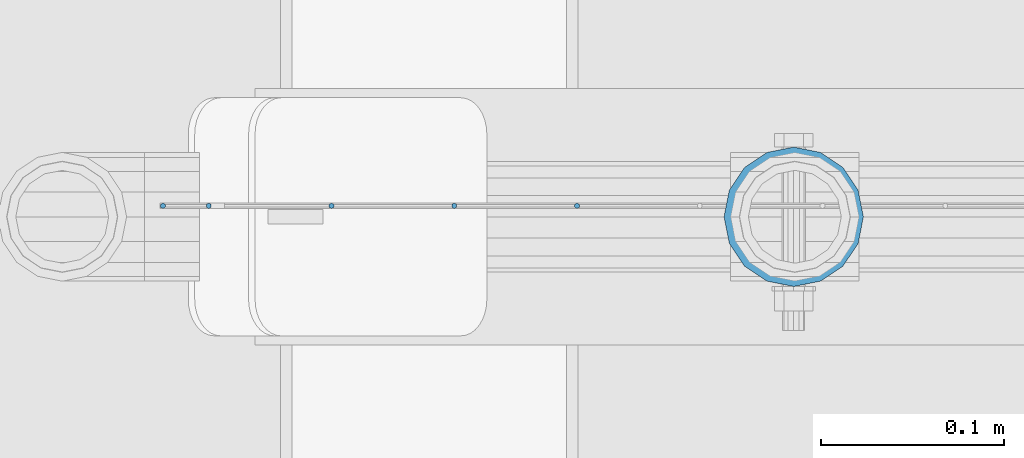
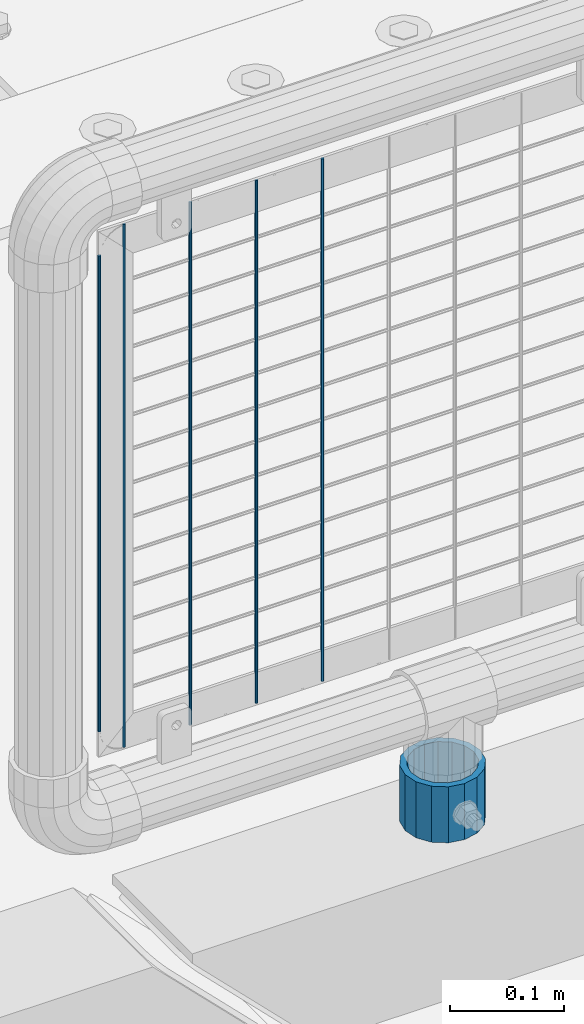
# One storey, part 110 of 270: 6 columns.
"""IFC2X3 building model written with IfcOpenShell, lengths in millimetres."""

from ifc_helpers import new_model, si_unit, frame, origin_with_axes, place, context, subcontext, project, spatial, faceted_brep, material, type_object, element, save


model = new_model("IFC2X3")

# Units and contexts
model_context = context("Model", 3, precision=1e-05, world=origin_with_axes())
body_context = subcontext(model_context, "Body", "Model", "MODEL_VIEW")
ifc_project = project(units=[si_unit("LENGTHUNIT", "METRE", prefix="MILLI"), si_unit("AREAUNIT", "SQUARE_METRE"), si_unit("VOLUMEUNIT", "CUBIC_METRE"), si_unit("MASSUNIT", "GRAM", prefix="KILO"), si_unit("TIMEUNIT", "SECOND"), si_unit("PLANEANGLEUNIT", "RADIAN"), si_unit("SOLIDANGLEUNIT", "STERADIAN"), si_unit("THERMODYNAMICTEMPERATUREUNIT", "DEGREE_CELSIUS"), si_unit("LUMINOUSINTENSITYUNIT", "LUMEN")], contexts=[model_context])

# Site, building, storey
site_placement = place(None, origin_with_axes())
site = spatial("IfcSite", under=ifc_project, at=site_placement, CompositionType="ELEMENT")
building_placement = place(site_placement, origin_with_axes())
building = spatial("IfcBuilding", under=site, at=building_placement, Name="Standard", CompositionType="ELEMENT")
storey_placement = place(building_placement, origin_with_axes())
storey = spatial("IfcBuildingStorey", under=building, at=storey_placement, Name="Undefined", CompositionType="ELEMENT", Elevation=0.0)

# Columns
ifc_material_1 = material()
column_type_1 = type_object("IfcColumnType", PredefinedType="NOTDEFINED")
column_1_placement = place(storey_placement, frame((19094.0, -16335.5, 168.019999999998), z_axis=(0.0, 1.0, 0.0), x_axis=(0.0, 0.0, 1.0)))
element("IfcColumn", 1, at=column_1_placement, inside=storey, type_object=column_type_1, material=ifc_material_1, context=body_context, shape_type="Brep", body=[
    faceted_brep([(0.0, -31.75, 0.0), (0.0, -29.3331751572332, 12.1501989775916), (60.0, -29.3331751572332, 12.1501989775916), (60.0, -31.75, 0.0), (0.0, -22.4506403026717, 22.4506403026735), (60.0, -22.4506403026717, 22.4506403026735), (0.0, -12.1501989775934, 29.3331751572332), (60.0, -12.1501989775934, 29.3331751572332), (0.0, 0.0, 31.75), (60.0, 0.0, 31.75), (0.0, 12.1501989775934, 29.3331751572332), (60.0, 12.1501989775934, 29.3331751572332), (0.0, 22.4506403026717, 22.4506403026735), (60.0, 22.4506403026717, 22.4506403026735), (0.0, 29.3331751572332, 12.1501989775916), (60.0, 29.3331751572332, 12.1501989775916), (0.0, 31.75, 0.0), (60.0, 31.75, 0.0), (0.0, 29.3331751572332, -12.1501989775916), (60.0, 29.3331751572332, -12.1501989775916), (0.0, 22.4506403026717, -22.4506403026735), (60.0, 22.4506403026717, -22.4506403026735), (0.0, 12.1501989775934, -29.3331751572332), (60.0, 12.1501989775934, -29.3331751572332), (0.0, 0.0, -31.75), (60.0, 0.0, -31.75), (0.0, -12.1501989775934, -29.3331751572332), (60.0, -12.1501989775934, -29.3331751572332), (0.0, -22.4506403026717, -22.4506403026735), (60.0, -22.4506403026717, -22.4506403026735), (0.0, -29.3331751572332, -12.1501989775916), (60.0, -29.3331751572332, -12.1501989775916), (0.0, -38.0499999999993, 0.0), (0.0, -35.1536162120537, -14.561104601491), (60.0, -35.1536162120537, -14.561104601491), (60.0, -38.0499999999993, 0.0), (0.0, -26.9054130241493, -26.9054130241475), (60.0, -26.9054130241493, -26.9054130241475), (0.0, -14.5611046014928, -35.1536162120537), (60.0, -14.5611046014928, -35.1536162120537), (0.0, 0.0, -38.0499999999993), (60.0, 0.0, -38.0499999999993), (0.0, 14.5611046014928, -35.1536162120537), (60.0, 14.5611046014928, -35.1536162120537), (0.0, 26.9054130241493, -26.9054130241475), (60.0, 26.9054130241493, -26.9054130241475), (0.0, 35.1536162120537, -14.561104601491), (60.0, 35.1536162120537, -14.561104601491), (0.0, 38.0499999999993, 0.0), (60.0, 38.0499999999993, 0.0), (0.0, 35.1536162120537, 14.561104601491), (60.0, 35.1536162120537, 14.561104601491), (0.0, 26.9054130241493, 26.9054130241475), (60.0, 26.9054130241493, 26.9054130241475), (0.0, 14.5611046014928, 35.1536162120537), (60.0, 14.5611046014928, 35.1536162120537), (0.0, 0.0, 38.0499999999993), (60.0, 0.0, 38.0499999999993), (0.0, -14.5611046014928, 35.1536162120537), (60.0, -14.5611046014928, 35.1536162120537), (0.0, -26.9054130241493, 26.9054130241475), (60.0, -26.9054130241493, 26.9054130241475), (0.0, -35.1536162120537, 14.561104601491), (60.0, -35.1536162120537, 14.561104601491)], [[[0, 1, 2, 3]], [[1, 4, 5, 2]], [[4, 6, 7, 5]], [[6, 8, 9, 7]], [[8, 10, 11, 9]], [[10, 12, 13, 11]], [[12, 14, 15, 13]], [[14, 16, 17, 15]], [[16, 18, 19, 17]], [[18, 20, 21, 19]], [[20, 22, 23, 21]], [[22, 24, 25, 23]], [[24, 26, 27, 25]], [[26, 28, 29, 27]], [[28, 30, 31, 29]], [[30, 0, 3, 31]], [[32, 33, 34, 35]], [[33, 36, 37, 34]], [[36, 38, 39, 37]], [[38, 40, 41, 39]], [[40, 42, 43, 41]], [[42, 44, 45, 43]], [[44, 46, 47, 45]], [[46, 48, 49, 47]], [[48, 50, 51, 49]], [[50, 52, 53, 51]], [[52, 54, 55, 53]], [[54, 56, 57, 55]], [[56, 58, 59, 57]], [[58, 60, 61, 59]], [[60, 62, 63, 61]], [[62, 32, 35, 63]], [[37, 39, 41, 43, 45, 47, 49, 51, 53, 55, 57, 59, 61, 63, 35, 34], [5, 7, 9, 11, 13, 15, 17, 19, 21, 23, 25, 27, 29, 31, 3, 2]], [[62, 60, 58, 56, 54, 52, 50, 48, 46, 44, 42, 40, 38, 36, 33, 32], [30, 28, 26, 24, 22, 20, 18, 16, 14, 12, 10, 8, 6, 4, 1, 0]]]),
])
ifc_material_2 = material(Name="Misc_Undefined")
column_type_2 = type_object("IfcColumnType", Name="D3", PredefinedType="NOTDEFINED")
for number, where, z_axis, x_axis in (
    (2, (18975.694, -16329.5000596021, 353.02), (-1.0, 0.0, 0.0), (0.0, 0.0, 1.0)),
    (3, (18908.666, -16329.5000453933, 353.02), (-1.0, 0.0, 0.0), (0.0, 0.0, 1.0)),
    (4, (18841.638, -16329.5000311845, 353.02), (-1.0, 0.0, 0.0), (0.0, 0.0, 1.0)),
):
    element("IfcColumn", number, at=place(storey_placement, frame(where, z_axis=z_axis, x_axis=x_axis)), inside=storey, type_object=column_type_2, material=ifc_material_2, ObjectType="D3", context=body_context, shape_type="Brep", body=[
        faceted_brep([(0.0, -1.5, 0.0), (0.0, -0.75, -1.29903810567669), (560.0, -0.75, -1.29903810567703), (560.0, -1.5, 0.0), (0.0, 0.75, -1.29903810567669), (560.0, 0.75, -1.29903810567703), (0.0, 1.5, 0.0), (560.0, 1.5, 0.0), (0.0, 0.75, 1.29903810567669), (560.0, 0.75, 1.29903810567703), (0.0, -0.75, 1.29903810567669), (560.0, -0.75, 1.29903810567703)], [[[0, 1, 2, 3]], [[1, 4, 5, 2]], [[4, 6, 7, 5]], [[6, 8, 9, 7]], [[8, 10, 11, 9]], [[10, 0, 3, 11]], [[5, 7, 9, 11, 3, 2]], [[10, 8, 6, 4, 1, 0]]]),
    ])
column_2_placement = place(storey_placement, frame((18749.61, -16329.5000116708, 378.02), z_axis=(-1.0, 0.0, 0.0), x_axis=(0.0, 0.0, 1.0)))
element("IfcColumn", 5, at=column_2_placement, inside=storey, type_object=column_type_2, material=ifc_material_2, ObjectType="D3", context=body_context, shape_type="Brep", body=[
    faceted_brep([(0.0, -1.5, 0.0), (0.0, -0.75, -1.29903810567669), (510.0, -0.75, -1.29903810567703), (510.0, -1.5, 0.0), (0.0, 0.75, -1.29903810567669), (510.0, 0.75, -1.29903810567703), (0.0, 1.5, 0.0), (510.0, 1.5, 0.0), (0.0, 0.75, 1.29903810567669), (510.0, 0.75, 1.29903810567703), (0.0, -0.75, 1.29903810567669), (510.0, -0.75, 1.29903810567703)], [[[0, 1, 2, 3]], [[1, 4, 5, 2]], [[4, 6, 7, 5]], [[6, 8, 9, 7]], [[8, 10, 11, 9]], [[10, 0, 3, 11]], [[5, 7, 9, 11, 3, 2]], [[10, 8, 6, 4, 1, 0]]]),
])
column_3_placement = place(storey_placement, frame((18774.61, -16329.5000169757, 353.02), z_axis=(-1.0, 0.0, 0.0), x_axis=(0.0, 0.0, 1.0)))
element("IfcColumn", 6, at=column_3_placement, inside=storey, type_object=column_type_2, material=ifc_material_2, ObjectType="D3", context=body_context, shape_type="Brep", body=[
    faceted_brep([(0.0, -1.5, 0.0), (0.0, -0.75, -1.29903810567669), (560.0, -0.75, -1.29903810567703), (560.0, -1.5, 0.0), (0.0, 0.75, -1.29903810567669), (560.0, 0.75, -1.29903810567703), (0.0, 1.5, 0.0), (560.0, 1.5, 0.0), (0.0, 0.75, 1.29903810567669), (560.0, 0.75, 1.29903810567703), (0.0, -0.75, 1.29903810567669), (560.0, -0.75, 1.29903810567703)], [[[0, 1, 2, 3]], [[1, 4, 5, 2]], [[4, 6, 7, 5]], [[6, 8, 9, 7]], [[8, 10, 11, 9]], [[10, 0, 3, 11]], [[5, 7, 9, 11, 3, 2]], [[10, 8, 6, 4, 1, 0]]]),
])

save(model, "model.ifc")
